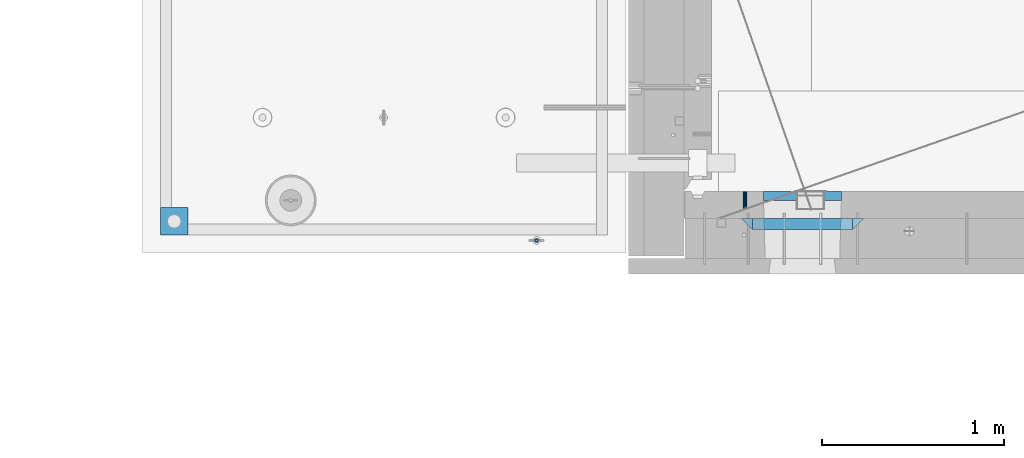
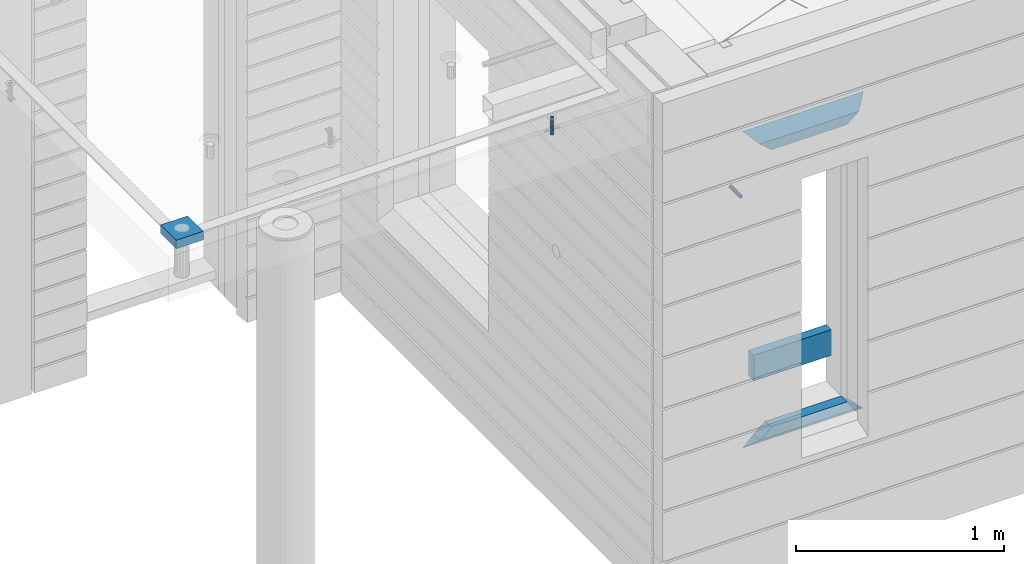
# One storey, part 131 of 341: 8 beams, 4 elements without a shape of their own.
"""IFC2X3 building model written with IfcOpenShell, lengths in millimetres."""

from ifc_helpers import new_model, si_unit, frame, origin_with_axes, place, context, subcontext, project, spatial, faceted_brep, material, type_object, element, aggregate, save


model = new_model("IFC2X3")

# Units and contexts
model_context = context("Model", 3, precision=1e-05, world=origin_with_axes())
body_context = subcontext(model_context, "Body", "Model", "MODEL_VIEW")
ifc_project = project(units=[si_unit("LENGTHUNIT", "METRE", prefix="MILLI"), si_unit("AREAUNIT", "SQUARE_METRE"), si_unit("VOLUMEUNIT", "CUBIC_METRE"), si_unit("MASSUNIT", "GRAM", prefix="KILO"), si_unit("TIMEUNIT", "SECOND"), si_unit("PLANEANGLEUNIT", "RADIAN"), si_unit("SOLIDANGLEUNIT", "STERADIAN"), si_unit("THERMODYNAMICTEMPERATUREUNIT", "DEGREE_CELSIUS"), si_unit("LUMINOUSINTENSITYUNIT", "LUMEN")], contexts=[model_context])

# Site, building, storey
site_placement = place(None, origin_with_axes())
site = spatial("IfcSite", under=ifc_project, at=site_placement, CompositionType="ELEMENT")
building_placement = place(site_placement, origin_with_axes())
building = spatial("IfcBuilding", under=site, at=building_placement, CompositionType="ELEMENT")
storey_placement = place(building_placement, origin_with_axes())
storey = spatial("IfcBuildingStorey", under=building, at=storey_placement, Name="5", CompositionType="ELEMENT", Elevation=0.0)

# Assembly, beam
assembly_1_placement = place(storey_placement, origin_with_axes())
assembly_1 = element("IfcElementAssembly", 1, at=assembly_1_placement, inside=storey, AssemblyPlace="NOTDEFINED", PredefinedType="REINFORCEMENT_UNIT")
ifc_material_1 = material(Name="CONCRETE/Concrete_Undefined")
beam_type_1 = type_object("IfcBeamType", PredefinedType="NOTDEFINED")
beam_1_placement = place(assembly_1_placement, frame((7135.00199083741, 7835.00021949177, 96683.0), z_axis=(0.0, 0.0, 1.0), x_axis=(0.999999999595185, 2.84539999907424e-05, 0.0)))
beam_1 = element("IfcBeam", 2, at=beam_1_placement, type_object=beam_type_1, material=ifc_material_1, context=body_context, shape_type="Brep", body=[
    faceted_brep([(0.0, 75.0, -25.0), (1.81898940354586e-12, 75.0, 25.0), (150.000890444859, 75.0000000000009, 25.0), (150.000890444859, 75.0000000000009, -25.0), (1.81898940354586e-12, -75.0000000000009, 25.0), (150.00089044486, -74.9999999999991, 25.0), (0.0, -75.0, -25.0), (150.00089044486, -74.9999999999991, -25.0)], [[[0, 1, 2, 3]], [[1, 4, 5, 2]], [[4, 6, 7, 5]], [[6, 0, 3, 7]], [[5, 7, 3, 2]], [[6, 4, 1, 0]]]),
])

# Assemblies, beam
assembly_2_placement = place(storey_placement, origin_with_axes())
assembly_2 = element("IfcElementAssembly", 3, at=assembly_2_placement, inside=storey, AssemblyPlace="NOTDEFINED", PredefinedType="REINFORCEMENT_UNIT")
assembly_3_placement = place(assembly_2_placement, origin_with_axes())
assembly_3 = element("IfcElementAssembly", 4, at=assembly_3_placement, Name="Steel Assembly", AssemblyPlace="NOTDEFINED", PredefinedType="RIGID_FRAME")
ifc_material_2 = material(Name="STEEL/Steel_Undefined")
beam_type_2 = type_object("IfcBeamType", PredefinedType="NOTDEFINED")
beam_2_placement = place(assembly_3_placement, frame((10344.9953216359, 8000.0, 95755.0), z_axis=(1.0, 0.0, 0.0), x_axis=(0.0, -1.0, 0.0)))
beam_2 = element("IfcBeam", 5, at=beam_2_placement, type_object=beam_type_2, material=ifc_material_2, Name="M16", context=body_context, shape_type="Brep", body=[
    faceted_brep([(0.0, -8.49999999999272, -1.45519152283669e-11), (0.0, -7.36121593215648, 4.24999999998545), (100.000000000262, -7.36121593215648, 4.24999999998545), (100.000000000262, -8.49999999999272, -1.45519152283669e-11), (0.0, -4.24999999998545, 7.36121593216376), (100.000000000262, -4.24999999998545, 7.36121593216376), (0.0, 1.45519152283669e-11, 8.49999999998545), (100.000000000262, 1.45519152283669e-11, 8.49999999998545), (0.0, 4.25000000001455, 7.36121593216376), (100.000000000262, 4.25000000001455, 7.36121593216376), (0.0, 7.36121593217104, 4.24999999998545), (100.000000000262, 7.36121593217104, 4.24999999998545), (0.0, 8.50000000000728, 0.0), (100.000000000262, 8.50000000000728, 0.0), (0.0, 7.36121593217104, -4.25000000001455), (100.000000000262, 7.36121593217104, -4.25000000001455), (0.0, 4.25000000000728, -7.36121593219286), (100.000000000262, 4.25000000000728, -7.36121593219286), (0.0, 7.27595761418343e-12, -8.5), (100.000000000262, 7.27595761418343e-12, -8.5), (0.0, -4.24999999999272, -7.36121593217831), (100.000000000262, -4.24999999999272, -7.36121593217831), (0.0, -7.36121593215648, -4.25), (100.000000000262, -7.36121593215648, -4.25), (0.0, -10.4999999999927, -1.45519152283669e-11), (0.0, -9.09326673972828, -5.25000000001455), (100.000000000262, -9.09326673972828, -5.25000000001455), (100.000000000262, -10.4999999999927, -1.45519152283669e-11), (0.0, -5.24999999998545, -9.09326673974283), (100.000000000262, -5.24999999998545, -9.09326673974283), (0.0, 7.27595761418343e-12, -10.5), (100.000000000262, 7.27595761418343e-12, -10.5), (0.0, 5.25000000001455, -9.09326673975738), (100.000000000262, 5.25000000001455, -9.09326673975738), (0.0, 9.09326673975011, -5.25000000001455), (100.000000000262, 9.09326673975011, -5.25000000001455), (0.0, 10.5000000000073, -1.45519152283669e-11), (100.000000000262, 10.5000000000073, -1.45519152283669e-11), (0.0, 9.09326673975011, 5.25), (100.000000000262, 9.09326673975011, 5.25), (0.0, 5.25000000000728, 9.09326673972828), (100.000000000262, 5.25000000000728, 9.09326673972828), (0.0, 1.45519152283669e-11, 10.4999999999854), (100.000000000262, 1.45519152283669e-11, 10.4999999999854), (0.0, -5.24999999999272, 9.09326673972828), (100.000000000262, -5.24999999999272, 9.09326673972828), (0.0, -9.09326673972828, 5.24999999998545), (100.000000000262, -9.09326673972828, 5.24999999998545)], [[[0, 1, 2, 3]], [[1, 4, 5, 2]], [[4, 6, 7, 5]], [[6, 8, 9, 7]], [[8, 10, 11, 9]], [[10, 12, 13, 11]], [[12, 14, 15, 13]], [[14, 16, 17, 15]], [[16, 18, 19, 17]], [[18, 20, 21, 19]], [[20, 22, 23, 21]], [[22, 0, 3, 23]], [[24, 25, 26, 27]], [[25, 28, 29, 26]], [[28, 30, 31, 29]], [[30, 32, 33, 31]], [[32, 34, 35, 33]], [[34, 36, 37, 35]], [[36, 38, 39, 37]], [[38, 40, 41, 39]], [[40, 42, 43, 41]], [[42, 44, 45, 43]], [[44, 46, 47, 45]], [[46, 24, 27, 47]], [[29, 31, 33, 35, 37, 39, 41, 43, 45, 47, 27, 26], [5, 7, 9, 11, 13, 15, 17, 19, 21, 23, 3, 2]], [[46, 44, 42, 40, 38, 36, 34, 32, 30, 28, 25, 24], [22, 20, 18, 16, 14, 12, 10, 8, 6, 4, 1, 0]]]),
])
aggregate(assembly_3, [beam_2])

# Assembly
assembly_4_placement = place(assembly_1_placement, origin_with_axes())
assembly_4 = element("IfcElementAssembly", 6, at=assembly_4_placement, Name="Steel Assembly", AssemblyPlace="NOTDEFINED", PredefinedType="RIGID_FRAME")

aggregate(assembly_1, [assembly_4, beam_1])

# Beam
ifc_material_3 = material(Name="STEEL/1.4301")
beam_type_3 = type_object("IfcBeamType", PredefinedType="NOTDEFINED")
beam_3_placement = place(assembly_4_placement, frame((9200.00647225436, 7729.99938297495, 96725.999999991), z_axis=(-3.40399999911671e-06, 0.999999999994206, 0.0), x_axis=(0.0, 0.0, -1.0)))
beam_3 = element("IfcBeam", 7, at=beam_3_placement, type_object=beam_type_3, material=ifc_material_3, context=body_context, shape_type="Brep", body=[
    faceted_brep([(0.0, -8.0, 0.0), (0.0, -6.92820323027263, 4.0), (100.000000000029, -6.92820323027263, 4.0), (100.000000000029, -7.99999999999636, 0.0), (0.0, -4.0, 6.92820323027627), (100.000000000029, -4.0, 6.92820323027536), (0.0, 0.0, 8.0), (100.000000000029, 3.63797880709171e-12, 8.0), (0.0, 4.0, 6.92820323027627), (100.000000000029, 4.0, 6.92820323027536), (0.0, 6.92820323027263, 4.0), (100.000000000029, 6.92820323027627, 3.99999999999909), (0.0, 8.0, 0.0), (100.000000000029, 8.0, 0.0), (0.0, 6.92820323027263, -4.0), (100.000000000029, 6.92820323027627, -4.00000000000091), (0.0, 4.0, -6.92820323027627), (100.000000000029, 4.00000000000364, -6.92820323027536), (0.0, 0.0, -8.0), (100.000000000029, 3.63797880709171e-12, -8.00000000000091), (0.0, -4.0, -6.92820323027627), (100.000000000029, -3.99999999999636, -6.92820323027627), (0.0, -6.92820323027263, -4.0), (100.000000000029, -6.92820323027263, -4.0), (0.0, -10.4999999999927, -1.45519152283669e-11), (0.0, -9.09326673972828, -5.25000000001455), (100.000000000262, -9.09326673972828, -5.25000000001455), (100.000000000262, -10.4999999999927, -1.45519152283669e-11), (0.0, -5.24999999998545, -9.09326673974283), (100.000000000262, -5.24999999998545, -9.09326673974283), (0.0, 7.27595761418343e-12, -10.5), (100.000000000262, 7.27595761418343e-12, -10.5), (0.0, 5.25000000001455, -9.09326673975738), (100.000000000262, 5.25000000001455, -9.09326673975738), (0.0, 9.09326673975011, -5.25000000001455), (100.000000000262, 9.09326673975011, -5.25000000001455), (0.0, 10.5000000000073, -1.45519152283669e-11), (100.000000000262, 10.5000000000073, -1.45519152283669e-11), (0.0, 9.09326673975011, 5.25), (100.000000000262, 9.09326673975011, 5.25), (0.0, 5.25000000000728, 9.09326673972828), (100.000000000262, 5.25000000000728, 9.09326673972828), (0.0, 1.45519152283669e-11, 10.4999999999854), (100.000000000262, 1.45519152283669e-11, 10.4999999999854), (0.0, -5.24999999999272, 9.09326673972828), (100.000000000262, -5.24999999999272, 9.09326673972828), (0.0, -9.09326673972828, 5.24999999998545), (100.000000000262, -9.09326673972828, 5.24999999998545)], [[[0, 1, 2, 3]], [[1, 4, 5, 2]], [[4, 6, 7, 5]], [[6, 8, 9, 7]], [[8, 10, 11, 9]], [[10, 12, 13, 11]], [[12, 14, 15, 13]], [[14, 16, 17, 15]], [[16, 18, 19, 17]], [[18, 20, 21, 19]], [[20, 22, 23, 21]], [[22, 0, 3, 23]], [[24, 25, 26, 27]], [[25, 28, 29, 26]], [[28, 30, 31, 29]], [[30, 32, 33, 31]], [[32, 34, 35, 33]], [[34, 36, 37, 35]], [[36, 38, 39, 37]], [[38, 40, 41, 39]], [[40, 42, 43, 41]], [[42, 44, 45, 43]], [[44, 46, 47, 45]], [[46, 24, 27, 47]], [[29, 31, 33, 35, 37, 39, 41, 43, 45, 47, 27, 26], [5, 7, 9, 11, 13, 15, 17, 19, 21, 23, 3, 2]], [[46, 44, 42, 40, 38, 36, 34, 32, 30, 28, 25, 24], [22, 20, 18, 16, 14, 12, 10, 8, 6, 4, 1, 0]]]),
])

aggregate(assembly_4, [beam_3])

ifc_material_4 = material(Name="TIMBER/T24")
beam_type_4 = type_object("IfcBeamType", PredefinedType="NOTDEFINED")
beam_4_placement = place(assembly_2_placement, frame((10445.0009023501, 7974.99972412935, 94685.0), z_axis=(0.0, 0.0, 1.0), x_axis=(1.0, 0.0, 0.0)))
beam_4 = element("IfcBeam", 8, at=beam_4_placement, type_object=beam_type_4, material=ifc_material_4, context=body_context, shape_type="Brep", body=[
    faceted_brep([(-3.63797880709171e-12, 24.9999999999964, -75.0), (-3.63797880709171e-12, 24.9999999999964, 75.0), (430.0, 25.0, 75.0), (430.0, 25.0, -75.0), (0.0, -25.0000000000073, 75.0), (430.0, -25.0, 75.0), (0.0, -25.0000000000073, -75.0), (430.0, -25.0, -75.0)], [[[0, 1, 2, 3]], [[1, 4, 5, 2]], [[4, 6, 7, 5]], [[6, 0, 3, 7]], [[5, 7, 3, 2]], [[6, 4, 1, 0]]]),
])

ifc_material_5 = material(Name="CONCRETE/C25/30")
beam_type_5 = type_object("IfcBeamType", PredefinedType="NOTDEFINED")
beam_5_placement = place(assembly_2_placement, frame((10324.997879677, 7820.0, 96145.0), z_axis=(0.0, 0.0, -1.0), x_axis=(1.0, 0.0, 0.0)))
beam_5 = element("IfcBeam", 9, at=beam_5_placement, type_object=beam_type_5, material=ifc_material_5, Name="SK", context=body_context, shape_type="Brep", body=[
    faceted_brep([(60.0000000000073, 30.0, 30.0), (0.0, -30.0, -30.0), (60.0000000000073, -30.0, 30.0), (670.001525878906, -30.0, -30.0), (610.001525878895, -30.0, 30.0), (610.001525878895, 30.0, 30.0)], [[[0, 1, 2]], [[2, 1, 3, 4]], [[0, 2, 4, 5]], [[1, 0, 5, 3]], [[4, 3, 5]]]),
])

beam_6_placement = place(assembly_2_placement, frame((10384.997879677, 7820.0, 96085.0), z_axis=(0.0, 0.0, -1.0), x_axis=(1.0, 0.0, 0.0)))
beam_6 = element("IfcBeam", 10, at=beam_6_placement, type_object=beam_type_5, material=ifc_material_5, Name="SK", context=body_context, shape_type="Brep", body=[
    faceted_brep([(485.947471824853, -30.0, 24.0540540540533), (484.325850203231, 30.0, 25.6756756756804), (65.6772015545812, 30.0, 25.6756756756804), (64.0555799329595, -30.0, 24.0540540540533), (65.6772015545812, 30.0, 26.2947441772849), (64.0555799329595, -30.0, 24.9047827876493), (0.0, -30.0, -30.0), (0.0, 30.0, -30.0), (550.001525878906, -30.0, -30.0), (485.947471824853, -30.0, 24.9034748914273), (484.325850203231, 30.0, 26.293436281092), (550.001525878906, 30.0, -30.0)], [[[0, 1, 2, 3]], [[3, 2, 4, 5]], [[6, 5, 4, 7]], [[0, 3, 5, 6, 8, 9]], [[1, 0, 9, 10]], [[7, 4, 2, 1, 10, 11]], [[6, 7, 11, 8]], [[10, 9, 8, 11]]]),
])

beam_7_placement = place(assembly_2_placement, frame((10994.9994055559, 7820.0, 94350.0), z_axis=(0.0, 0.0, 1.0), x_axis=(-1.0, 3.00000001838171e-08, 0.0)))
beam_7 = element("IfcBeam", 11, at=beam_7_placement, type_object=beam_type_5, material=ifc_material_5, Name="SK", context=body_context, shape_type="Brep", body=[
    faceted_brep([(610.001525878895, -30.0, 30.0), (670.001525878906, -30.0, -30.0), (610.001525878895, 30.0, 30.0), (0.0, -30.0, -30.0), (60.0000000000073, 30.0, 30.0), (60.0000000000073, -30.0, 30.0)], [[[0, 1, 2]], [[3, 4, 2, 1]], [[4, 5, 0, 2]], [[5, 3, 1, 0]], [[4, 3, 5]]]),
])

beam_8_placement = place(assembly_2_placement, frame((10934.9994055559, 7820.0, 94410.0), z_axis=(0.0, 0.0, 1.0), x_axis=(-1.0, 3.00000001838171e-08, 0.0)))
beam_8 = element("IfcBeam", 12, at=beam_8_placement, type_object=beam_type_5, material=ifc_material_5, Name="SK", context=body_context, shape_type="Brep", body=[
    faceted_brep([(485.945945945947, -30.0, 24.0540540540533), (484.324324324325, 30.0, 25.6756756756804), (65.6756756756768, 30.0, 25.6756756756804), (64.0540540540533, -30.0, 24.0540540540533), (485.945945945947, -30.0, 24.9047827876348), (484.324324324325, 30.0, 26.2947441772849), (550.001525878906, -30.0, -30.0), (550.001525878906, 30.0, -30.0), (0.0, -30.0, -30.0), (0.0, 30.0, -30.0), (65.6756756756768, 30.0, 26.293436281092), (64.0540540540533, -30.0, 24.9034748914419)], [[[0, 1, 2, 3]], [[1, 0, 4, 5]], [[6, 7, 5, 4]], [[8, 9, 7, 6]], [[2, 1, 5, 7, 9, 10]], [[3, 2, 10, 11]], [[6, 4, 0, 3, 11, 8]], [[8, 11, 10, 9]]]),
])

aggregate(assembly_2, [assembly_3, beam_5, beam_6, beam_7, beam_8, beam_4])

save(model, "model.ifc")
